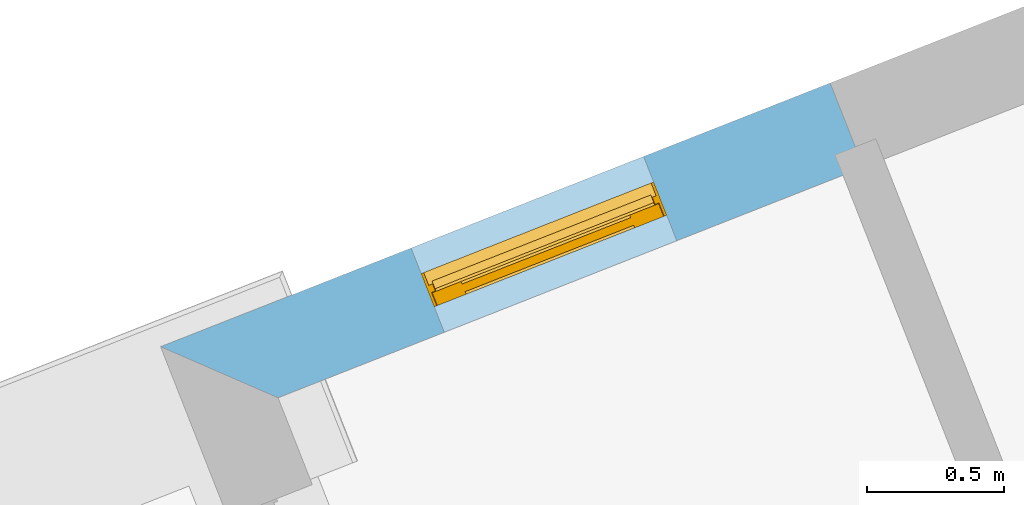
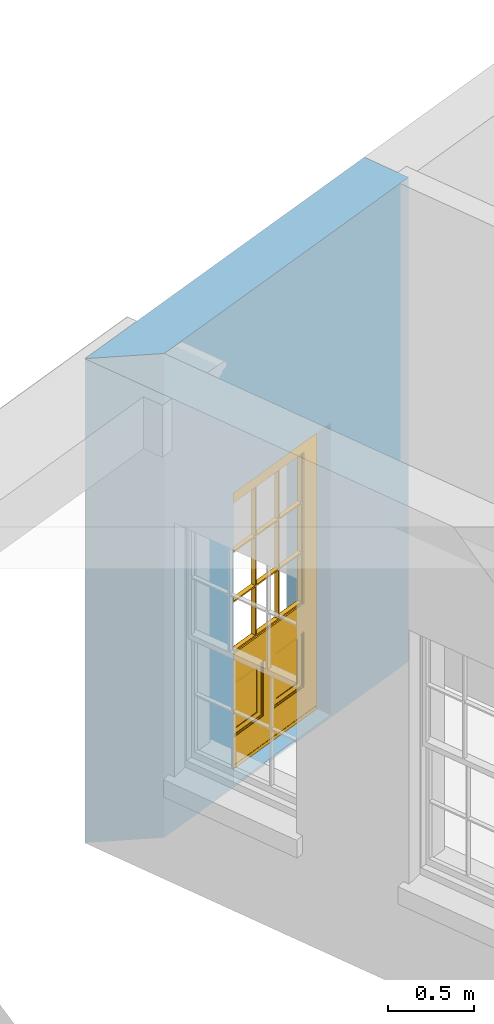
# One storey, part 4 of 8: 1 door, 1 opening, plus 1 element that does not belong to this part.
"""IFC2X3 building model written with IfcOpenShell, lengths in metres."""

import ifcopenshell
import ifcopenshell.guid

model = None  # the IFC model being written
_history = None  # IfcOwnerHistory: only IFC2X3 demands one
_inside = {}  # id of a spatial element -> (the spatial element, [elements in it])
_under = {}  # id of a project, library or spatial element -> (it, [spatial elements below it])
_declared = {}  # id of a project -> (the project, [libraries it declares])
_typed = {}  # id of a type object -> (the type object, [elements of that type])
_made_of = {}  # id of a material, layer set ... -> (it, [elements and type objects made of it])


def new_model(schema):
    """Start an empty IFC model of exactly this schema.

    Asked for "IFC4X3", IfcOpenShell would pick the latest addendum, in which some entities
    have other attributes; the version numbers below select the first issue.
    IFC2X3 requires an IfcOwnerHistory on every rooted entity: one is made here for all.
    """
    global model, _history
    if schema == "IFC4X3":
        model = ifcopenshell.file(schema_version=(4, 3, 0, 0))
    else:
        model = ifcopenshell.file(schema=schema)
    _inside.clear()
    _under.clear()
    _declared.clear()
    _typed.clear()
    _made_of.clear()
    _history = None
    if model.schema == "IFC2X3":
        org = make("IfcOrganization", Name="unknown")
        user = make(
            "IfcPersonAndOrganization",
            ThePerson=make("IfcPerson", FamilyName="unknown"),
            TheOrganization=org,
        )
        app = make(
            "IfcApplication",
            ApplicationDeveloper=org,
            Version="unknown",
            ApplicationFullName="unknown",
            ApplicationIdentifier="unknown",
        )
        _history = make(
            "IfcOwnerHistory",
            OwningUser=user,
            OwningApplication=app,
            ChangeAction="ADDED",
            CreationDate=0,
        )
    return model


def make(cls, **values):
    """One entity of the class cls with the attributes given. An attribute that is None is left unset."""
    return model.create_entity(
        cls, **{name: value for name, value in values.items() if value is not None}
    )


def rooted(cls, **values):
    """An entity with a GlobalId (a new one), such as an element, a storey or a relation."""
    return make(cls, GlobalId=ifcopenshell.guid.new(), OwnerHistory=_history, **values)


def si_unit(unit_type, name, prefix=None):
    """IfcSIUnit, for example si_unit("LENGTHUNIT", "METRE", prefix="MILLI")."""
    return make("IfcSIUnit", UnitType=unit_type, Prefix=prefix, Name=name)


def assignment(units):
    """IfcUnitAssignment: the units of a project."""
    return None if units is None else make("IfcUnitAssignment", Units=units)


def point(xyz):
    """IfcCartesianPoint."""
    return None if xyz is None else make("IfcCartesianPoint", Coordinates=xyz)


def direction(xyz):
    """IfcDirection."""
    return None if xyz is None else make("IfcDirection", DirectionRatios=xyz)


def frame(location, z_axis=None, x_axis=None):
    """IfcAxis2Placement3D, a coordinate frame: its origin and axes. An axis left out is left unset."""
    return make(
        "IfcAxis2Placement3D",
        Location=point(location),
        Axis=direction(z_axis),
        RefDirection=direction(x_axis),
    )


def origin():
    """The frame at (0, 0, 0) with its axes left unset."""
    return frame((0.0, 0.0, 0.0))


def place(relative_to, where):
    """IfcLocalPlacement: puts the frame where relative to a parent placement (None: the world)."""
    return make(
        "IfcLocalPlacement", PlacementRelTo=relative_to, RelativePlacement=where
    )


def context(
    kind, dimensions, precision=None, world=None, true_north=None, identifier=None
):
    """IfcGeometricRepresentationContext, for example the 3D "Model" context."""
    return make(
        "IfcGeometricRepresentationContext",
        ContextIdentifier=identifier,
        ContextType=kind,
        CoordinateSpaceDimension=dimensions,
        Precision=precision,
        WorldCoordinateSystem=world,
        TrueNorth=true_north,
    )


def subcontext(parent, identifier, kind, view, scale=None):
    """IfcGeometricRepresentationSubContext, for example "Body" below "Model"."""
    return make(
        "IfcGeometricRepresentationSubContext",
        ContextIdentifier=identifier,
        ContextType=kind,
        ParentContext=parent,
        TargetScale=scale,
        TargetView=view,
    )


def project(units=None, contexts=None):
    """IfcProject with its units and contexts."""
    return rooted(
        "IfcProject",
        Name="project",
        RepresentationContexts=contexts,
        UnitsInContext=assignment(units),
    )


def spatial(cls, under=None, at=None, **own):
    """A site, building, storey or space (cls), placed at a placement, below another one or the project."""
    s = rooted(cls, ObjectPlacement=at, **own)
    if under is not None:
        _under.setdefault(under.id(), (under, []))[1].append(s)
    return s


def polyline(points):
    """IfcPolyline through the points."""
    return make("IfcPolyline", Points=[point(p) for p in points])


def outline(outer, holes=None, kind="AREA"):
    """IfcArbitraryClosedProfileDef: a profile drawn as a closed curve; with holes, ...WithVoids."""
    if holes is None:
        return make("IfcArbitraryClosedProfileDef", ProfileType=kind, OuterCurve=outer)
    return make(
        "IfcArbitraryProfileDefWithVoids",
        ProfileType=kind,
        OuterCurve=outer,
        InnerCurves=holes,
    )


def extrude(swept, where, along, depth):
    """IfcExtrudedAreaSolid: the profile swept, set in the frame where, extruded along a direction by depth."""
    return make(
        "IfcExtrudedAreaSolid",
        SweptArea=swept,
        Position=where,
        ExtrudedDirection=direction(along),
        Depth=depth,
    )


def faces_of(points, faces, orient=None, outer=None):
    """IfcFace entities. A face is a list of loops; a loop is a list of indices into points, from 0.

    orient and outer hold one flag for each loop. By default every Orientation is true, the
    first loop of a face is its IfcFaceOuterBound and the others are IfcFaceBound.
    """
    made = []
    for i, loops in enumerate(faces):
        bounds = []
        for j, loop in enumerate(loops):
            is_outer = j == 0 if outer is None else outer[i][j]
            bounds.append(
                make(
                    "IfcFaceOuterBound" if is_outer else "IfcFaceBound",
                    Bound=make("IfcPolyLoop", Polygon=[points[k] for k in loop]),
                    Orientation=True if orient is None else orient[i][j],
                )
            )
        made.append(make("IfcFace", Bounds=bounds))
    return made


def faceted_brep(points, faces, orient=None, outer=None, voids=None):
    """IfcFacetedBrep: a solid bounded by flat faces; with voids (closed shells), ...WithVoids."""
    shared = [point(p) for p in points]
    hull = make("IfcClosedShell", CfsFaces=faces_of(shared, faces, orient, outer))
    if voids is None:
        return make("IfcFacetedBrep", Outer=hull)
    return make(
        "IfcFacetedBrepWithVoids",
        Outer=hull,
        Voids=[
            make(cls, CfsFaces=faces_of(shared, fs, o, b)) for cls, fs, o, b in voids
        ],
    )


def shape(context_of_items, identifier, shape_type, items):
    """IfcShapeRepresentation: the items that make up one representation, for example the "Body"."""
    return make(
        "IfcShapeRepresentation",
        ContextOfItems=context_of_items,
        RepresentationIdentifier=identifier,
        RepresentationType=shape_type,
        Items=items,
    )


def material(Name=None, Category=None):
    """IfcMaterial."""
    return make("IfcMaterial", Name=Name, Category=Category)


def layer(
    of_material, thickness, ventilated=None, Name=None, Category=None, Priority=None
):
    """IfcMaterialLayer: one layer of a wall or slab, of a material (None: an air gap)."""
    return make(
        "IfcMaterialLayer",
        Material=of_material,
        LayerThickness=thickness,
        IsVentilated=ventilated,
        Name=Name,
        Category=Category,
        Priority=Priority,
    )


def layer_set(layers, Name=None):
    """IfcMaterialLayerSet."""
    return make("IfcMaterialLayerSet", MaterialLayers=layers, LayerSetName=Name)


def layer_usage(for_layer_set, set_direction, sense, offset, extent=None):
    """IfcMaterialLayerSetUsage: how a layer set lies in its element."""
    return make(
        "IfcMaterialLayerSetUsage",
        ForLayerSet=for_layer_set,
        LayerSetDirection=set_direction,
        DirectionSense=sense,
        OffsetFromReferenceLine=offset,
        ReferenceExtent=extent,
    )


def made_of(thing, what):
    """Note that an element or type object is made of a material, layer set ...; save() writes the relation."""
    if what is not None:
        _made_of.setdefault(what.id(), (what, []))[1].append(thing)
    return thing


def element(
    cls,
    number,
    at=None,
    inside=None,
    cuts=None,
    type_object=None,
    material=None,
    context=None,
    identifier="Body",
    shape_type=None,
    held_by="IfcProductDefinitionShape",
    body=None,
    shapes=None,
    **own,
):
    """One element of the class cls, such as IfcWall. Its Tag is "e" and its number.

    at: its placement. inside: the storey or other place that contains it. cuts: it is an
    opening in that element (IfcRelVoidsElement). A single representation is given by context,
    identifier, shape_type and body (its items); several are given by shapes. held_by: the class
    of the entity that holds the representations. save() writes the other relations.
    """
    e = rooted(cls, Tag="e%d" % number, ObjectPlacement=at, **own)
    if body is not None:
        shapes = [shape(context, identifier, shape_type, body)]
    if shapes is not None:
        e.Representation = make(held_by, Representations=shapes)
    if inside is not None:
        _inside.setdefault(inside.id(), (inside, []))[1].append(e)
    if cuts is not None:
        rooted(
            "IfcRelVoidsElement", RelatingBuildingElement=cuts, RelatedOpeningElement=e
        )
    if type_object is not None:
        _typed.setdefault(type_object.id(), (type_object, []))[1].append(e)
    return made_of(e, material)


def fill(opening, filler):
    """IfcRelFillsElement: the door or window that sits in an opening."""
    return rooted(
        "IfcRelFillsElement",
        RelatingOpeningElement=opening,
        RelatedBuildingElement=filler,
    )


def aggregate(whole, parts):
    """IfcRelAggregates: a whole, such as a stair, and the parts it consists of."""
    return rooted("IfcRelAggregates", RelatingObject=whole, RelatedObjects=parts)


def save(model, path):
    """Write the relations noted so far, then the file.

    IfcRelAggregates (storeys below a building ...), IfcRelContainedInSpatialStructure (elements
    in a storey), IfcRelDefinesByType, IfcRelAssociatesMaterial and IfcRelDeclares: one each for
    every whole, place, type object, material and project.
    """
    for whole, parts in _under.values():
        aggregate(whole, parts)
    for where, things in _inside.values():
        rooted(
            "IfcRelContainedInSpatialStructure",
            RelatedElements=things,
            RelatingStructure=where,
        )
    for kind, things in _typed.values():
        rooted("IfcRelDefinesByType", RelatedObjects=things, RelatingType=kind)
    for what, things in _made_of.values():
        rooted("IfcRelAssociatesMaterial", RelatedObjects=things, RelatingMaterial=what)
    for by, libraries in _declared.values():
        rooted("IfcRelDeclares", RelatingContext=by, RelatedDefinitions=libraries)
    model.write(path)


model = new_model("IFC2X3")

# Units and contexts
model_context = context("Model", 3, world=origin())
body_context = subcontext(model_context, "Body", "Model", "MODEL_VIEW")
ifc_project = project(units=[si_unit("PLANEANGLEUNIT", "RADIAN"), si_unit("MASSUNIT", "GRAM", prefix="KILO"), si_unit("FORCEUNIT", "NEWTON", prefix="KILO"), si_unit("LENGTHUNIT", "METRE")], contexts=[model_context])

# Site, building, storey
site_placement = place(None, origin())
site = spatial("IfcSite", under=ifc_project, at=site_placement, CompositionType="ELEMENT")
building_placement = place(None, origin())
building = spatial("IfcBuilding", under=site, at=building_placement, Name="Building plot-4", CompositionType="ELEMENT")
storey_placement = place(None, frame((0.0, 0.0, 3.0)))
storey = spatial("IfcBuildingStorey", under=building, at=storey_placement, Name="Floor 0", CompositionType="ELEMENT", Elevation=3.0)

# Wall, opening, door
ifc_material = material(Name="Masonry")
ifc_layer = layer(ifc_material, 0.33, ventilated=False)
ifc_layer_set = layer_set([ifc_layer], Name="My Wall")
ifc_layer_usage = layer_usage(ifc_layer_set, "AXIS2", "NEGATIVE", 0.08)
wall_placement = place(storey_placement, origin())
wall = element("IfcWallStandardCase", 1, at=wall_placement, inside=storey, material=ifc_layer_usage, Name="exterior", context=body_context, shape_type="SweptSolid", body=[
    extrude(outline(polyline([(49.6583212938703, 52.8365801850812), (49.5373999145512, 53.1436274453256), (47.0988755747214, 52.1832875730829), (47.5268442142849, 51.9971616921577), (49.6583212938703, 52.8365801850812)])), origin(), (0.0, 0.0, 1.0), 3.45),
])
opening_placement = place(storey_placement, frame((0.0, 0.0, 0.02)))
opening = element("IfcOpeningElement", 2, at=opening_placement, cuts=wall, Name="Opening", ObjectType="Opening", context=body_context, shape_type="SweptSolid", body=[
    extrude(outline(polyline([(48.8577965656718, 52.8759859940682), (48.011090484392, 52.5425361298851), (48.1320118637111, 52.2354888696407), (48.978717944991, 52.5689387338238), (48.8577965656718, 52.8759859940682)])), origin(), (0.0, 0.0, 1.0), 2.08),
])
door_placement = place(storey_placement, frame((48.9494036712166, 52.643374433277, 0.02), z_axis=(0.0, 0.0, 1.0), x_axis=(-0.846706081279848, -0.333449864183095, 0.0)))
door = element("IfcDoor", 3, at=door_placement, inside=storey, Name="toilet door", OverallHeight=2.08, OverallWidth=0.91, context=body_context, shape_type="Brep", held_by="IfcProductRepresentation", body=[
    faceted_brep([(0.545, -0.055, 0.265), (0.745, -0.055, 0.265), (0.745, -0.05, 0.265), (0.545, -0.05, 0.265), (0.745, -0.05, 0.58), (0.545, -0.05, 0.58), (0.545, -0.055, 0.58), (0.515, -0.06, 0.235), (0.775, -0.06, 0.235), (0.745, -0.055, 0.58), (0.515, -0.06, 0.61), (0.515, -0.065, 0.235), (0.775, -0.065, 0.235), (0.775, -0.06, 0.61), (0.515, -0.065, 0.61), (0.785, -0.065, 0.225), (0.505, -0.065, 0.225), (0.775, -0.065, 0.61), (0.505, -0.065, 0.62), (0.785, -0.065, 0.62), (0.505, -0.07, 0.225), (0.785, -0.07, 0.225), (0.505, -0.07, 0.62), (0.785, -0.07, 0.62), (0.883, -0.07, 0.075), (0.898, -0.07, 0.075), (0.405, -0.07, 0.62), (0.405, -0.07, 0.225), (0.027, -0.07, 0.075), (0.785, -0.07, 0.82), (0.125, -0.07, 0.82), (0.405, -0.065, 0.62), (0.405, -0.065, 0.225), (0.898, -0.07, 2.068), (0.027, -0.08, 0.075), (0.883, -0.08, 0.075), (0.125, -0.07, 0.225), (0.012, -0.07, 0.075), (0.785, -0.06, 0.82), (0.125, -0.06, 0.82), (0.125, -0.07, 0.62), (0.125, -0.065, 0.62), (0.395, -0.065, 0.61), (0.395, -0.065, 0.235), (0.125, -0.065, 0.225), (0.785, -0.07, 1.895), (0.027, -0.11, 0.045), (0.883, -0.11, 0.045), (0.558333, -0.06, 0.83), (0.351667, -0.06, 0.83), (0.125, -0.07, 1.895), (0.125, -0.06, 1.895), (0.785, -0.06, 1.895), (0.012, -0.07, 2.068), (0.135, -0.065, 0.61), (0.395, -0.06, 0.61), (0.395, -0.06, 0.235), (0.135, -0.065, 0.235), (0.027, -0.11, 0.027), (0.883, -0.11, 0.027), (0.568333, -0.06, 0.83), (0.558333, -0.03, 0.83), (0.351667, -0.03, 0.83), (0.341667, -0.06, 0.83), (0.135, -0.06, 1.185), (0.135, -0.06, 1.53), (0.775, -0.06, 1.53), (0.775, -0.06, 1.185), (0.135, -0.06, 0.61), (0.365, -0.055, 0.58), (0.365, -0.055, 0.265), (0.135, -0.06, 0.235), (0.568333, -0.06, 1.175), (0.558333, -0.06, 1.175), (0.775, -0.06, 0.83), (0.558333, -0.03, 1.175), (0.785, -0.03, 0.82), (0.125, -0.03, 0.82), (0.351667, -0.03, 1.175), (0.351667, -0.06, 1.175), (0.341667, -0.06, 1.175), (0.135, -0.06, 0.83), (0.135, -0.06, 1.175), (0.135, -0.03, 1.185), (0.135, -0.03, 1.53), (0.135, -0.06, 1.54), (0.351667, -0.06, 1.885), (0.558333, -0.06, 1.885), (0.775, -0.03, 1.53), (0.775, -0.03, 1.185), (0.775, -0.06, 1.175), (0.775, -0.06, 1.54), (0.165, -0.055, 0.58), (0.365, -0.05, 0.58), (0.365, -0.05, 0.265), (0.165, -0.055, 0.265), (0.568333, -0.03, 0.83), (0.568333, -0.03, 1.175), (0.568333, -0.06, 1.185), (0.558333, -0.06, 1.185), (0.775, -0.03, 0.83), (0.785, -0.02, 0.82), (0.125, -0.02, 0.82), (0.341667, -0.03, 0.83), (0.341667, -0.03, 1.175), (0.351667, -0.06, 1.185), (0.341667, -0.06, 1.185), (0.135, -0.03, 0.83), (0.341667, -0.03, 1.185), (0.125, -0.03, 1.895), (0.341667, -0.03, 1.53), (0.341667, -0.06, 1.53), (0.135, -0.06, 1.885), (0.341667, -0.06, 1.54), (0.341667, -0.06, 1.885), (0.558333, -0.03, 1.885), (0.351667, -0.03, 1.885), (0.568333, -0.06, 1.885), (0.785, -0.03, 1.895), (0.568333, -0.03, 1.185), (0.568333, -0.06, 1.53), (0.568333, -0.03, 1.53), (0.568333, -0.06, 1.54), (0.775, -0.06, 1.885), (0.165, -0.05, 0.58), (0.165, -0.05, 0.265), (0.775, -0.03, 1.175), (0.558333, -0.06, 1.53), (0.351667, -0.03, 1.185), (0.558333, -0.03, 1.185), (0.505, -0.02, 0.62), (0.405, -0.02, 0.62), (0.125, -0.02, 1.895), (0.785, -0.02, 1.895), (0.351667, -0.06, 1.53), (0.135, -0.03, 1.175), (0.135, -0.03, 1.54), (0.341667, -0.03, 1.54), (0.135, -0.03, 1.885), (0.351667, -0.06, 1.54), (0.558333, -0.03, 1.54), (0.558333, -0.06, 1.54), (0.351667, -0.03, 1.54), (0.775, -0.03, 1.54), (0.568333, -0.03, 1.54), (0.775, -0.03, 1.885), (0.558333, -0.03, 1.53), (0.405, -0.02, 0.225), (0.505, -0.02, 0.225), (0.125, -0.02, 0.62), (0.785, -0.02, 0.62), (0.012, -0.02, 2.068), (0.898, -0.02, 2.068), (0.351667, -0.03, 1.53), (0.341667, -0.03, 1.885), (0.568333, -0.03, 1.885), (0.405, -0.025, 0.225), (0.405, -0.025, 0.62), (0.505, -0.025, 0.62), (0.505, -0.025, 0.225), (0.898, -0.02, 0.027), (0.012, -0.02, 0.027), (0.125, -0.025, 0.62), (0.785, -0.025, 0.62), (0.395, -0.025, 0.235), (0.395, -0.025, 0.61), (0.125, -0.02, 0.225), (0.125, -0.025, 0.225), (0.515, -0.025, 0.61), (0.515, -0.025, 0.235), (0.785, -0.02, 0.225), (0.785, -0.025, 0.225), (0.135, -0.025, 0.61), (0.775, -0.025, 0.61), (0.135, -0.025, 0.235), (0.395, -0.03, 0.235), (0.395, -0.03, 0.61), (0.515, -0.03, 0.61), (0.515, -0.03, 0.235), (0.775, -0.025, 0.235), (0.135, -0.03, 0.61), (0.775, -0.03, 0.61), (0.135, -0.03, 0.235), (0.365, -0.035, 0.265), (0.365, -0.035, 0.58), (0.545, -0.035, 0.58), (0.545, -0.035, 0.265), (0.775, -0.03, 0.235), (0.165, -0.035, 0.58), (0.745, -0.035, 0.58), (0.165, -0.035, 0.265), (0.365, -0.04, 0.58), (0.365, -0.04, 0.265), (0.545, -0.04, 0.58), (0.545, -0.04, 0.265), (0.745, -0.035, 0.265), (0.165, -0.04, 0.58), (0.745, -0.04, 0.58), (0.165, -0.04, 0.265), (0.745, -0.04, 0.265), (0.885, -0.072, 0.025), (0.025, -0.072, 0.025), (0.025, -0.1, 0.025), (0.885, -0.1, 0.025), (0.9, -0.02, 0.025), (0.01, -0.02, 0.025), (0.9, -0.072, 0.025), (0.91, -0.02, 0.0), (0.0, -0.02, 0.0), (0.01, -0.072, 0.025), (0.9, -0.072, 2.07), (0.9, -0.02, 2.07), (0.885, -0.072, 2.055), (0.91, -0.02, 2.08), (0.01, -0.02, 2.07), (0.0, -0.02, 2.08), (0.01, -0.072, 2.07), (0.025, -0.072, 2.055), (0.0, -0.15, 2.08), (0.91, -0.15, 2.08), (0.01, -0.15, 2.07), (0.9, -0.15, 2.07), (0.01, -0.1, 2.07), (0.9, -0.1, 2.07), (0.0, -0.15, 0.0), (0.91, -0.15, 0.0), (0.01, -0.15, 0.025), (0.9, -0.15, 0.025), (0.01, -0.1, 0.025), (0.025, -0.1, 2.055), (0.9, -0.1, 0.025), (0.885, -0.1, 2.055), (0.898, -0.07, 0.027), (0.012, -0.07, 0.027), (0.883, -0.07, 0.027), (0.027, -0.07, 0.027)], [[[0, 1, 2, 3]], [[2, 4, 5, 3]], [[0, 3, 5, 6]], [[1, 0, 7, 8]], [[9, 4, 2, 1]], [[9, 6, 5, 4]], [[0, 6, 10, 7]], [[8, 7, 11, 12]], [[8, 13, 9, 1]], [[13, 10, 6, 9]], [[7, 10, 14, 11]], [[15, 12, 11, 16]], [[12, 17, 13, 8]], [[17, 14, 10, 13]], [[18, 16, 11, 14]], [[15, 19, 17, 12]], [[15, 16, 20, 21]], [[14, 17, 19, 18]], [[16, 18, 22, 20]], [[21, 23, 19, 15]], [[24, 25, 21, 20]], [[23, 22, 18, 19]], [[20, 22, 26, 27]], [[23, 21, 25]], [[28, 24, 20, 27]], [[22, 23, 29]], [[29, 30, 26, 22]], [[27, 26, 31, 32]], [[23, 25, 33, 29]], [[34, 35, 24, 28]], [[28, 27, 36, 37]], [[38, 39, 30, 29]], [[26, 30, 40]], [[26, 40, 41, 31]], [[42, 43, 32, 31]], [[32, 44, 36, 27]], [[33, 45, 29]], [[46, 47, 35, 34]], [[36, 40, 37]], [[39, 38, 48, 49]], [[50, 30, 39, 51]], [[29, 45, 52, 38]], [[53, 37, 40, 30]], [[44, 41, 40, 36]], [[31, 41, 54, 42]], [[43, 42, 55, 56]], [[57, 44, 32, 43]], [[50, 45, 33, 53]], [[47, 46, 58, 59]], [[60, 48, 38]], [[49, 48, 61, 62]], [[49, 63, 39]], [[50, 53, 30]], [[51, 39, 64, 65]], [[45, 50, 51, 52]], [[66, 67, 38, 52]], [[57, 54, 41, 44]], [[42, 54, 68, 55]], [[56, 55, 69, 70]], [[56, 71, 57, 43]], [[60, 72, 73, 48]], [[60, 38, 74]], [[48, 73, 75, 61]], [[76, 77, 62, 61]], [[62, 78, 79, 49]], [[49, 79, 80, 63]], [[63, 81, 39]], [[82, 64, 39]], [[65, 64, 83, 84]], [[85, 51, 65]], [[52, 51, 86, 87]], [[88, 89, 67, 66]], [[90, 38, 67]], [[91, 66, 52]], [[71, 68, 54, 57]], [[55, 68, 92, 69]], [[69, 93, 94, 70]], [[70, 95, 71, 56]], [[96, 97, 72, 60]], [[73, 72, 98, 99]], [[74, 38, 90]], [[100, 96, 60, 74]], [[75, 73, 79, 78]], [[61, 75, 97, 96]], [[101, 102, 77, 76]], [[77, 103, 62]], [[96, 76, 61]], [[103, 104, 78, 62]], [[80, 79, 105, 106]], [[63, 80, 104, 103]], [[81, 63, 103, 107]], [[81, 82, 39]], [[106, 64, 82, 80]], [[106, 108, 83, 64]], [[84, 83, 77, 109]], [[110, 111, 65, 84]], [[112, 51, 85]], [[113, 85, 65, 111]], [[114, 86, 51]], [[115, 87, 86, 116]], [[117, 52, 87]], [[118, 76, 89, 88]], [[119, 98, 67, 89]], [[120, 121, 88, 66]], [[67, 98, 72, 90]], [[91, 122, 120, 66]], [[91, 52, 123]], [[95, 92, 68, 71]], [[69, 92, 124, 93]], [[94, 93, 124, 125]], [[94, 125, 95, 70]], [[72, 97, 126, 90]], [[127, 99, 98, 120]], [[99, 105, 79, 73]], [[74, 90, 126, 100]], [[96, 100, 76]], [[128, 129, 75, 78]], [[97, 75, 129, 119]], [[130, 131, 102, 101]], [[109, 77, 102, 132]], [[133, 101, 76, 118]], [[77, 107, 103]], [[78, 104, 108, 128]], [[111, 106, 105, 134]], [[104, 80, 82, 135]], [[107, 135, 82, 81]], [[110, 108, 106, 111]], [[104, 135, 83, 108]], [[83, 135, 77]], [[136, 84, 109]], [[110, 84, 136, 137]], [[114, 51, 112]], [[85, 136, 138, 112]], [[113, 137, 136, 85]], [[111, 134, 139, 113]], [[86, 114, 113, 139]], [[140, 141, 87, 115]], [[139, 142, 116, 86]], [[109, 118, 115, 116]], [[117, 123, 52]], [[117, 87, 141, 122]], [[126, 89, 76]], [[143, 118, 88]], [[120, 98, 119, 121]], [[119, 89, 126, 97]], [[144, 143, 88, 121]], [[144, 122, 91, 143]], [[127, 120, 122, 141]], [[143, 91, 123, 145]], [[124, 92, 95, 125]], [[146, 129, 99, 127]], [[99, 129, 128, 105]], [[100, 126, 76]], [[121, 119, 129, 146]], [[147, 131, 130, 148]], [[131, 149, 102]], [[130, 101, 150]], [[102, 151, 132]], [[118, 109, 132, 133]], [[101, 133, 152]], [[107, 77, 135]], [[153, 128, 108, 110]], [[134, 105, 128, 153]], [[109, 138, 136]], [[153, 110, 137, 142]], [[154, 114, 112, 138]], [[137, 113, 114, 154]], [[141, 139, 134, 127]], [[141, 140, 142, 139]], [[144, 140, 115, 155]], [[142, 137, 154, 116]], [[155, 115, 118]], [[116, 154, 109]], [[117, 155, 145, 123]], [[122, 144, 155, 117]], [[143, 145, 118]], [[121, 146, 140, 144]], [[146, 127, 134, 153]], [[156, 157, 131, 147]], [[148, 130, 158, 159]], [[148, 160, 161, 147]], [[157, 162, 149, 131]], [[161, 151, 102, 149]], [[101, 152, 160, 150]], [[163, 158, 130, 150]], [[151, 152, 133, 132]], [[154, 138, 109]], [[142, 140, 146, 153]], [[145, 155, 118]], [[157, 156, 164, 165]], [[147, 166, 167, 156]], [[168, 169, 159, 158]], [[170, 148, 159, 171]], [[148, 170, 160]], [[166, 147, 161]], [[172, 162, 157, 165]], [[166, 149, 162, 167]], [[166, 161, 149]], [[150, 160, 170]], [[163, 173, 168, 158]], [[171, 163, 150, 170]], [[174, 164, 156, 167]], [[175, 176, 165, 164]], [[169, 168, 177, 178]], [[171, 159, 169, 179]], [[167, 162, 172, 174]], [[176, 180, 172, 165]], [[179, 173, 163, 171]], [[181, 177, 168, 173]], [[164, 174, 182, 175]], [[183, 184, 176, 175]], [[178, 177, 185, 186]], [[179, 169, 178, 187]], [[174, 172, 180, 182]], [[184, 188, 180, 176]], [[187, 181, 173, 179]], [[189, 185, 177, 181]], [[175, 182, 190, 183]], [[191, 184, 183, 192]], [[185, 193, 194, 186]], [[187, 178, 186, 195]], [[182, 180, 188, 190]], [[191, 196, 188, 184]], [[195, 189, 181, 187]], [[197, 193, 185, 189]], [[183, 190, 198, 192]], [[198, 196, 191, 192]], [[194, 193, 197, 199]], [[195, 186, 194, 199]], [[188, 196, 198, 190]], [[197, 189, 195, 199]], [[200, 201, 202, 203]], [[201, 200, 204, 205]], [[206, 204, 200]], [[204, 207, 208, 205]], [[209, 201, 205]], [[210, 211, 204, 206]], [[206, 200, 212, 210]], [[211, 213, 207, 204]], [[214, 205, 208, 215]], [[216, 217, 201, 209]], [[205, 214, 216, 209]], [[216, 214, 211, 210]], [[210, 212, 217, 216]], [[214, 215, 213, 211]], [[218, 219, 213, 215]], [[219, 218, 220, 221]], [[221, 220, 222, 223]], [[215, 208, 224, 218]], [[225, 224, 208, 207]], [[224, 226, 220, 218]], [[224, 225, 227, 226]], [[219, 225, 207, 213]], [[228, 222, 220, 226]], [[219, 221, 227, 225]], [[226, 227, 203, 202]], [[202, 229, 222, 228]], [[228, 226, 202]], [[227, 221, 223, 230]], [[230, 203, 227]], [[217, 229, 202, 201]], [[231, 223, 222, 229]], [[230, 223, 231, 203]], [[231, 229, 217, 212]], [[212, 200, 203, 231]], [[33, 152, 151, 53]], [[25, 160, 152, 33]], [[161, 37, 53, 151]], [[232, 160, 25]], [[161, 233, 37]], [[160, 232, 234]], [[24, 234, 232, 25]], [[233, 161, 235]], [[37, 233, 235, 28]], [[161, 160, 234, 235]], [[35, 47, 234, 24]], [[28, 235, 46, 34]], [[58, 235, 234, 59]], [[59, 234, 47]], [[58, 46, 235]]]),
])
fill(opening, door)

save(model, "model.ifc")
